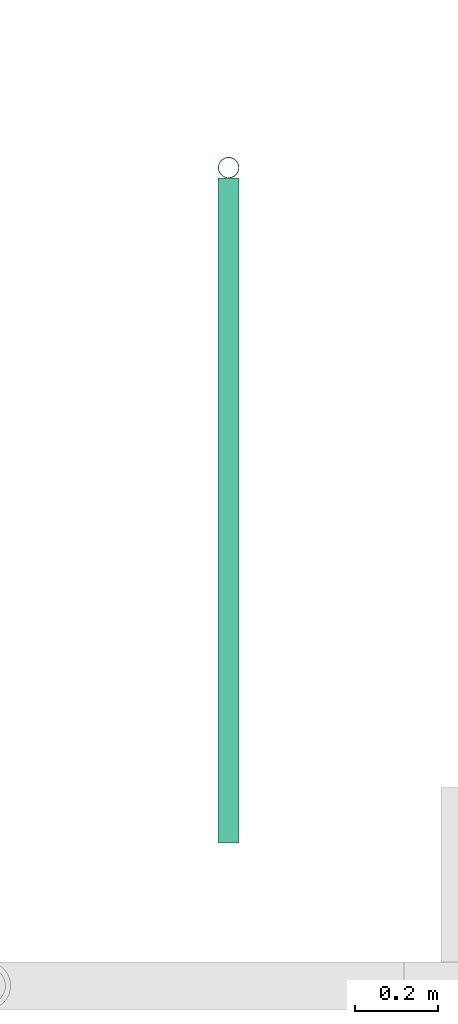
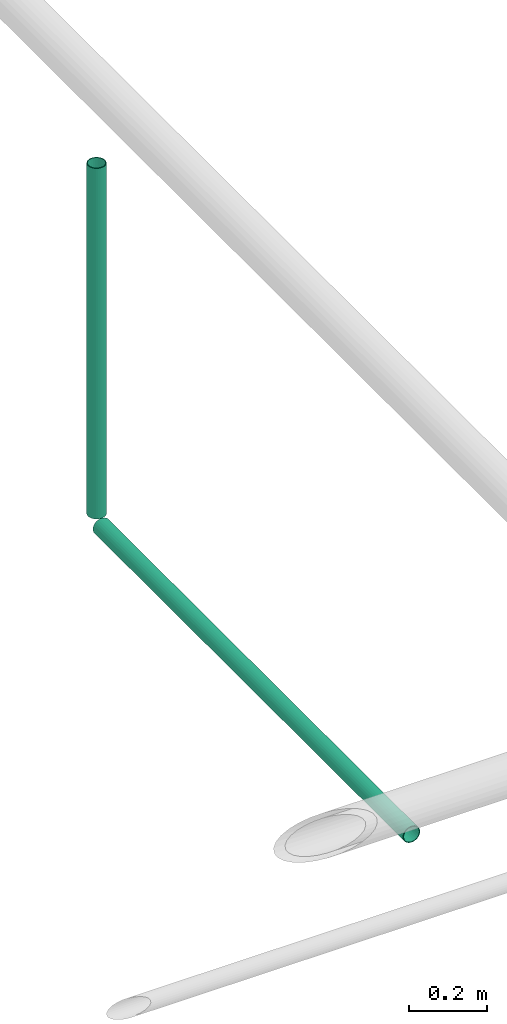
# One storey, part 8 of 15: 2 pipe segments.
"""IFC4X3_ADD2 building model written with IfcOpenShell, lengths in metres."""

from ifc_helpers import new_model, entity, si_unit, converted_unit, frame, origin_with_axes, origin_2d_with_axis, place, context, subcontext, project, spatial, hollow_circle, extrude, material, material_profile, profile_set, profile_usage, type_object, element, save


model = new_model("IFC4X3_ADD2")

# Units and contexts
model_context = context("Model", 3, precision=1e-05, world=origin_with_axes())
plan_context = context("Plan", 2, precision=1e-05, world=origin_2d_with_axis())
body_context = subcontext(model_context, "Body", "Model", "MODEL_VIEW")
ifc_project = project(units=[si_unit("VOLUMEUNIT", "CUBIC_METRE"), si_unit("LENGTHUNIT", "METRE"), converted_unit("PLANEANGLEUNIT", "degree", entity("IfcReal", 0.0174532925199433), si_unit("PLANEANGLEUNIT", "RADIAN"), dimensions=[0, 0, 0, 0, 0, 0, 0]), si_unit("AREAUNIT", "SQUARE_METRE")], contexts=[model_context, plan_context])

# Site, building, storey
site_placement = place(None, origin_with_axes())
site = spatial("IfcSite", under=ifc_project, at=site_placement)
building_placement = place(site_placement, origin_with_axes())
building = spatial("IfcBuilding", under=site, at=building_placement, Name="Building")
storey_placement = place(building_placement, origin_with_axes())
storey = spatial("IfcBuildingStorey", under=building, at=storey_placement, Name="Plumbing")

# Pipe segments
ifc_material = material(Name="Wall")
ifc_material_profile_1 = material_profile(ifc_material, hollow_circle(Radius=0.0253999996930361, WallThickness=0.0020000000949949))
ifc_profile_set_1 = profile_set([ifc_material_profile_1])
ifc_profile_usage_1 = profile_usage(ifc_profile_set_1)
ifc_material_profile_2 = material_profile(ifc_material, hollow_circle(Radius=0.0253999996930361, WallThickness=0.0020000000949949))
ifc_profile_set_2 = profile_set([ifc_material_profile_2])
pipe_segment_type = type_object("IfcPipeSegmentType", Name="2inch-bath outlet", PredefinedType="FLEXIBLESEGMENT", material=ifc_profile_set_2)
pipe_segment_1_placement = place(storey_placement, frame((28.5909576416016, 21.7649459838867, 0.0504299513995647), z_axis=(-8.74227481517655e-08, -1.19209317972489e-07, 0.999999999999989), x_axis=(-0.999999999999921, -3.89414367418763e-07, -8.7422797889751e-08)))
element("IfcPipeSegment", 1, at=pipe_segment_1_placement, inside=storey, type_object=pipe_segment_type, material=ifc_profile_usage_1, Name="PipeSegment", context=body_context, shape_type="SweptSolid", body=[
    extrude(hollow_circle(Radius=0.0253999996930361, WallThickness=0.0020000000949949), origin_with_axes(), (0.0, 0.0, 1.0), 1.09957002125543),
])
ifc_profile_usage_2 = profile_usage(ifc_profile_set_1)
pipe_segment_2_placement = place(storey_placement, frame((28.5909576416016, 20.1467037200928, 0.0252151470631361), z_axis=(-1.50995774106375e-07, 0.999999999999986, 7.54979012640422e-08), x_axis=(-0.999999999999913, -1.50995802528073e-07, 3.89414424262179e-07)))
element("IfcPipeSegment", 2, at=pipe_segment_2_placement, inside=storey, type_object=pipe_segment_type, material=ifc_profile_usage_2, Name="PipeSegment", context=body_context, shape_type="SweptSolid", body=[
    extrude(hollow_circle(Radius=0.0253999996930361, WallThickness=0.0020000000949949), origin_with_axes(), (0.0, 0.0, 1.0), 1.59302713793229),
])

save(model, "model.ifc")
